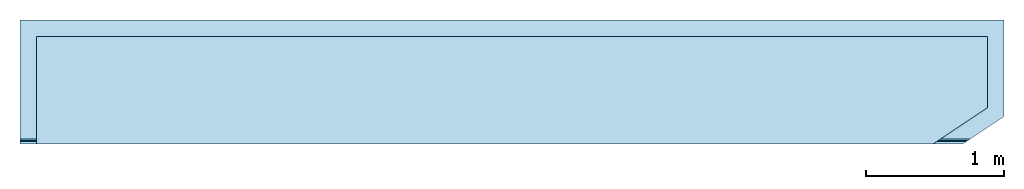
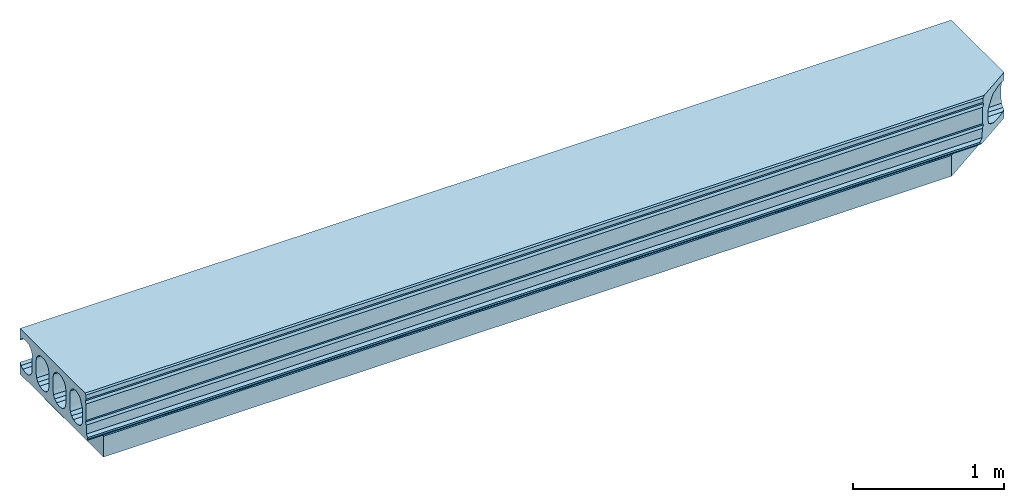
# One storey: 2 slabs.
"""IFC2X3 building model written with IfcOpenShell, lengths in millimetres."""

from ifc_helpers import new_model, si_unit, frame, origin_with_axes, place, context, subcontext, project, spatial, faceted_brep, material, type_object, element, save


model = new_model("IFC2X3")

# Units and contexts
model_context = context("Model", 3, precision=1e-05, world=origin_with_axes())
body_context = subcontext(model_context, "Body", "Model", "MODEL_VIEW")
ifc_project = project(units=[si_unit("LENGTHUNIT", "METRE", prefix="MILLI"), si_unit("AREAUNIT", "SQUARE_METRE"), si_unit("VOLUMEUNIT", "CUBIC_METRE"), si_unit("MASSUNIT", "GRAM", prefix="KILO"), si_unit("TIMEUNIT", "SECOND"), si_unit("PLANEANGLEUNIT", "RADIAN"), si_unit("SOLIDANGLEUNIT", "STERADIAN"), si_unit("THERMODYNAMICTEMPERATUREUNIT", "DEGREE_CELSIUS"), si_unit("LUMINOUSINTENSITYUNIT", "LUMEN")], contexts=[model_context])

# Site, building, storey
site_placement = place(None, origin_with_axes())
site = spatial("IfcSite", under=ifc_project, at=site_placement, CompositionType="ELEMENT")
building_placement = place(site_placement, origin_with_axes())
building = spatial("IfcBuilding", under=site, at=building_placement, Name="Undefined", CompositionType="ELEMENT")
storey_placement = place(building_placement, origin_with_axes())
storey = spatial("IfcBuildingStorey", under=building, at=storey_placement, Name="Undefined", CompositionType="ELEMENT", Elevation=0.0)

# Slabs
ifc_material_1 = material(Name="CONCRETE/Concrete_Undefined")
slab_type_1 = type_object("IfcSlabType", Name="EO37", PredefinedType="NOTDEFINED")
slab_1_placement = place(storey_placement, frame((0.0, 0.0, 185.0), z_axis=(0.0, 0.0, 1.0), x_axis=(1.0, 0.0, 0.0)))
element("IfcSlab", 1, at=slab_1_placement, inside=storey, type_object=slab_type_1, material=ifc_material_1, ObjectType="EO37", PredefinedType="FLOOR", context=body_context, shape_type="Brep", body=[
    faceted_brep([(0.0, -409.398748676134, -124.290964938346), (0.0, -438.100006103516, -130.0), (7082.9999688171, -438.100006103516, -130.0), (7126.05185754527, -409.398748676134, -124.290964938346), (7140.0, -385.066997514525, -108.033008588991), (0.0, -385.066997514525, -108.033008588991), (7140.0, -400.099987598431, -118.07773142711), (0.0, -368.809041165169, -83.7012574273817), (7140.0, -368.809041165169, -83.7012574273817), (0.0, -363.100006103516, -55.0), (7140.0, -363.100006103516, -55.0), (0.0, -363.100006103516, 55.0), (7140.0, -363.100006103516, 55.0), (0.0, -368.809041165169, 83.7012574273817), (7140.0, -368.809041165169, 83.7012574273817), (0.0, -385.066997514525, 108.033008588991), (7140.0, -385.066997514525, 108.033008588991), (0.0, -409.398748676134, 124.290964938347), (7140.0, -400.099987598431, 118.07773142711), (7126.05185754527, -409.398748676134, 124.290964938347), (0.0, -438.100006103516, 130.0), (7082.9999688171, -438.100006103516, 130.0), (0.0, -440.905458547625, 130.0), (7078.79178989805, -440.905458547625, 130.0), (0.0, -444.476831797178, 129.864952985487), (7073.4347297018, -444.476831797178, 129.864952985487), (0.0, -448.027807676442, 129.460583243007), (7068.10826556283, -448.027807676442, 129.460583243007), (0.0, -451.538105311693, 128.789200270557), (7062.84281879354, -451.538105311693, 128.789200270557), (0.0, -454.987676156985, 127.85463857272), (7057.66846221466, -454.987676156985, 127.85463857272), (0.0, -474.113683490167, 121.888653832883), (7028.97944949089, -474.113683490167, 121.888653832883), (0.0, -483.190791183214, 117.975054935726), (7015.36378713312, -483.190791183214, 117.975054935726), (0.0, -491.256055131865, 112.260017067295), (7003.26589048315, -491.256055131865, 112.260017067295), (0.0, -497.957099488949, 104.993233396137), (6993.2143233435, -497.957099488949, 104.993233396137), (0.0, -503.001151916536, 96.4921937240296), (6985.64824424746, -503.001151916536, 96.4921937240296), (0.0, -526.058454074776, 46.3241102051714), (6951.06228893174, -526.058454074776, 46.3241102051714), (0.0, -529.022615447613, 38.8403279823523), (6946.6160466053, -529.022615447613, 38.8403279823523), (0.0, -531.167660399297, 31.0819756342013), (6943.39847898442, -531.167660399297, 31.0819756342013), (0.0, -532.468880586419, 23.1384200683711), (6941.44664858645, -532.468880586419, 23.1384200683711), (0.0, -532.911287514118, 15.1011615113052), (6940.78303815502, -532.911287514118, 15.1011615113052), (0.0, -533.002319524285, -54.9024708467264), (6940.64649013156, -533.002319524285, -54.9024708467264), (0.0, -527.321307017782, -83.6336648774161), (6949.1680094034, -527.321307017782, -83.6336648774161), (0.0, -511.069862086386, -107.998515608949), (6973.54517826538, -511.069862086386, -107.998515608949), (0.0, -486.72616515099, -124.281630576477), (7010.06072586278, -486.72616515099, -124.281630576477), (0.0, -458.002382937217, -130.0), (7053.14640177257, -458.002382937217, -130.0), (0.0, 299.900024414063, -185.0), (0.0, 299.900024414063, -88.6264888460579), (7140.0, 299.900024414063, -88.6264888460579), (7140.0, 299.900024414063, -185.0), (0.0, 286.933002485475, -108.033008588991), (7140.0, 286.933002485475, -108.033008588991), (0.0, 262.601251323866, -124.290964938346), (7140.0, 262.601251323866, -124.290964938346), (0.0, 233.899993896484, -130.0), (7140.0, 233.899993896484, -130.0), (0.0, 213.899993896484, -130.0), (7140.0, 213.899993896484, -130.0), (0.0, 185.198736469103, -124.290964938347), (7140.0, 185.198736469103, -124.290964938347), (0.0, 160.866985307493, -108.033008588991), (7140.0, 160.866985307493, -108.033008588991), (0.0, 144.609028958138, -83.7012574273817), (7140.0, 144.609028958138, -83.7012574273817), (0.0, 138.899993896484, -55.0), (7140.0, 138.899993896484, -55.0), (0.0, 138.899993896484, 55.0), (7140.0, 138.899993896484, 55.0), (0.0, 144.609028958138, 83.7012574273817), (7140.0, 144.609028958138, 83.7012574273817), (0.0, 160.866985307493, 108.033008588991), (7140.0, 160.866985307493, 108.033008588991), (0.0, 185.198736469103, 124.290964938347), (7140.0, 185.198736469103, 124.290964938347), (0.0, 213.899993896484, 130.0), (7140.0, 213.899993896484, 130.0), (0.0, 233.899993896484, 130.0), (7140.0, 233.899993896484, 130.0), (0.0, 262.601251323866, 124.290964938347), (7140.0, 262.601251323866, 124.290964938347), (0.0, 286.933002485475, 108.033008588991), (7140.0, 286.933002485475, 108.033008588991), (0.0, 299.900024414063, 88.6264888460579), (7140.0, 299.900024414063, 88.6264888460579), (0.0, 299.900024414063, 185.0), (7140.0, 299.900024414063, 185.0), (0.0, -185.398748676134, -124.290964938346), (0.0, -214.100006103516, -130.0), (7140.0, -214.100006103516, -130.0), (7140.0, -185.398748676134, -124.290964938346), (0.0, -161.066997514525, -108.033008588991), (7140.0, -161.066997514525, -108.033008588991), (0.0, -144.809041165169, -83.7012574273817), (7140.0, -144.809041165169, -83.7012574273817), (0.0, -139.100006103516, -55.0), (7140.0, -139.100006103516, -55.0), (0.0, -139.100006103516, 55.0), (7140.0, -139.100006103516, 55.0), (0.0, -144.809041165169, 83.7012574273817), (7140.0, -144.809041165169, 83.7012574273817), (0.0, -161.066997514525, 108.033008588991), (7140.0, -161.066997514525, 108.033008588991), (0.0, -185.398748676134, 124.290964938347), (7140.0, -185.398748676134, 124.290964938347), (0.0, -214.100006103516, 130.0), (7140.0, -214.100006103516, 130.0), (0.0, -234.100006103516, 130.0), (7140.0, -234.100006103516, 130.0), (0.0, -262.801263530897, 124.290964938347), (7140.0, -262.801263530897, 124.290964938347), (0.0, -287.133014692507, 108.033008588991), (7140.0, -287.133014692507, 108.033008588991), (0.0, -303.390971041862, 83.7012574273817), (7140.0, -303.390971041862, 83.7012574273817), (0.0, -309.100006103516, 55.0), (7140.0, -309.100006103516, 55.0), (0.0, -309.100006103516, -55.0), (7140.0, -309.100006103516, -55.0), (0.0, -303.390971041862, -83.7012574273817), (7140.0, -303.390971041862, -83.7012574273817), (0.0, -287.133014692507, -108.033008588991), (7140.0, -287.133014692507, -108.033008588991), (0.0, -262.801263530897, -124.290964938347), (7140.0, -262.801263530897, -124.290964938347), (0.0, -234.100006103516, -130.0), (7140.0, -234.100006103516, -130.0), (0.0, -587.070007324219, -185.0), (0.0, -597.099975585938, -170.960006713867), (0.0, -600.099975585938, -155.0), (0.0, -581.919982910156, -137.149993896484), (0.0, -580.070007324219, -65.4400024414063), (0.0, -570.739990234375, -46.5400009155273), (0.0, -579.840026855469, -27.5400009155273), (0.0, -577.330017089844, 103.709999084473), (0.0, -567.640014648438, 122.650001525879), (0.0, -576.739990234375, 141.880004882813), (0.0, -575.22998046875, 174.970001220703), (0.0, -565.039978027344, 185.0), (0.0, 38.6012589532606, -124.290964938347), (0.0, 62.93301011487, -108.033008588991), (0.0, 79.1909664642254, -83.7012574273817), (0.0, 84.9000015258789, -55.0), (0.0, 84.9000015258789, 55.0), (0.0, 79.1909664642254, 83.7012574273817), (0.0, 62.93301011487, 108.033008588991), (0.0, 38.6012589532606, 124.290964938347), (0.0, 9.90000152587889, 130.0), (0.0, -10.0999984741211, 130.0), (0.0, -38.8012559015028, 124.290964938347), (0.0, -63.1330070631122, 108.033008588991), (0.0, -79.3909634124676, 83.7012574273817), (0.0, -85.0999984741211, 55.0), (0.0, -85.0999984741211, -55.0), (0.0, -79.3909634124676, -83.7012574273817), (0.0, -63.1330070631121, -108.033008588991), (0.0, -38.8012559015028, -124.290964938347), (0.0, -10.0999984741211, -130.0), (0.0, 9.90000152587889, -130.0), (7140.0, 9.90000152587889, -130.0), (7140.0, 38.6012589532606, -124.290964938347), (7140.0, 62.93301011487, -108.033008588991), (7140.0, 79.1909664642254, -83.7012574273817), (7140.0, 84.9000015258789, -55.0), (7140.0, 84.9000015258789, 55.0), (7140.0, 79.1909664642254, 83.7012574273817), (7140.0, 62.93301011487, 108.033008588991), (7140.0, 38.6012589532606, 124.290964938347), (7140.0, 9.90000152587889, 130.0), (7140.0, -10.0999984741211, 130.0), (7140.0, -38.8012559015028, 124.290964938347), (7140.0, -63.1330070631122, 108.033008588991), (7140.0, -79.3909634124676, 83.7012574273817), (7140.0, -85.0999984741211, 55.0), (7140.0, -85.0999984741211, -55.0), (7140.0, -79.3909634124676, -83.7012574273817), (7140.0, -63.1330070631121, -108.033008588991), (7140.0, -38.8012559015028, -124.290964938347), (7140.0, -10.0999984741211, -130.0), (7140.0, -400.099987598432, -185.0), (7140.0, -400.099987598432, 185.0), (6859.54495355807, -587.070007324219, -185.0), (6844.5000002614, -597.099975585938, -170.960006713867), (6839.99999999098, -600.099975585938, -155.0), (6867.26999064338, -581.919982910156, -137.149993896484), (6870.04495418904, -580.070007324219, -65.4400024414063), (6884.0399806648, -570.739990234375, -46.5400009155273), (6870.38992491289, -579.840026855469, -27.5400009155273), (6874.15493978758, -577.330017089844, 103.709999084473), (6888.68994432313, -567.640014648438, 122.650001525879), (6875.03998012397, -576.739990234375, 141.880004882813), (6877.30499490851, -575.22998046875, 174.970001220703), (6892.58999948914, -565.039978027344, 185.0)], [[[0, 1, 2, 3]], [[4, 5, 0, 3, 6]], [[7, 5, 4, 8]], [[9, 7, 8, 10]], [[11, 9, 10, 12]], [[13, 11, 12, 14]], [[15, 13, 14, 16]], [[17, 15, 16, 18, 19]], [[20, 17, 19, 21]], [[22, 20, 21, 23]], [[24, 22, 23, 25]], [[26, 24, 25, 27]], [[28, 26, 27, 29]], [[30, 28, 29, 31]], [[32, 30, 31, 33]], [[34, 32, 33, 35]], [[36, 34, 35, 37]], [[38, 36, 37, 39]], [[40, 38, 39, 41]], [[42, 40, 41, 43]], [[44, 42, 43, 45]], [[46, 44, 45, 47]], [[48, 46, 47, 49]], [[50, 48, 49, 51]], [[52, 50, 51, 53]], [[54, 52, 53, 55]], [[56, 54, 55, 57]], [[58, 56, 57, 59]], [[60, 58, 59, 61]], [[1, 60, 61, 2]], [[62, 63, 64, 65]], [[66, 67, 64, 63]], [[66, 68, 69, 67]], [[68, 70, 71, 69]], [[70, 72, 73, 71]], [[72, 74, 75, 73]], [[74, 76, 77, 75]], [[76, 78, 79, 77]], [[78, 80, 81, 79]], [[80, 82, 83, 81]], [[82, 84, 85, 83]], [[84, 86, 87, 85]], [[86, 88, 89, 87]], [[88, 90, 91, 89]], [[90, 92, 93, 91]], [[92, 94, 95, 93]], [[94, 96, 97, 95]], [[97, 96, 98, 99]], [[98, 100, 101, 99]], [[102, 103, 104, 105]], [[106, 102, 105, 107]], [[108, 106, 107, 109]], [[110, 108, 109, 111]], [[112, 110, 111, 113]], [[114, 112, 113, 115]], [[116, 114, 115, 117]], [[118, 116, 117, 119]], [[120, 118, 119, 121]], [[122, 120, 121, 123]], [[124, 122, 123, 125]], [[126, 124, 125, 127]], [[128, 126, 127, 129]], [[130, 128, 129, 131]], [[132, 130, 131, 133]], [[134, 132, 133, 135]], [[136, 134, 135, 137]], [[138, 136, 137, 139]], [[140, 138, 139, 141]], [[103, 140, 141, 104]], [[96, 94, 92, 90, 88, 86, 84, 82, 80, 78, 76, 74, 72, 70, 68, 66, 63, 62, 142, 143, 144, 145, 146, 147, 148, 149, 150, 151, 152, 153, 100, 98], [102, 106, 108, 110, 112, 114, 116, 118, 120, 122, 124, 126, 128, 130, 132, 134, 136, 138, 140, 103], [154, 155, 156, 157, 158, 159, 160, 161, 162, 163, 164, 165, 166, 167, 168, 169, 170, 171, 172, 173], [0, 5, 7, 9, 11, 13, 15, 17, 20, 22, 24, 26, 28, 30, 32, 34, 36, 38, 40, 42, 44, 46, 48, 50, 52, 54, 56, 58, 60, 1]], [[154, 173, 174, 175]], [[155, 154, 175, 176]], [[156, 155, 176, 177]], [[157, 156, 177, 178]], [[158, 157, 178, 179]], [[159, 158, 179, 180]], [[160, 159, 180, 181]], [[161, 160, 181, 182]], [[162, 161, 182, 183]], [[163, 162, 183, 184]], [[164, 163, 184, 185]], [[165, 164, 185, 186]], [[166, 165, 186, 187]], [[167, 166, 187, 188]], [[168, 167, 188, 189]], [[169, 168, 189, 190]], [[170, 169, 190, 191]], [[171, 170, 191, 192]], [[172, 171, 192, 193]], [[173, 172, 193, 174]], [[16, 14, 12, 10, 8, 4, 6, 194, 65, 64, 67, 69, 71, 73, 75, 77, 79, 81, 83, 85, 87, 89, 91, 93, 95, 97, 99, 101, 195, 18], [192, 191, 190, 189, 188, 187, 186, 185, 184, 183, 182, 181, 180, 179, 178, 177, 176, 175, 174, 193], [139, 137, 135, 133, 131, 129, 127, 125, 123, 121, 119, 117, 115, 113, 111, 109, 107, 105, 104, 141]], [[142, 62, 65, 194, 196]], [[143, 142, 196, 197]], [[144, 143, 197, 198]], [[145, 144, 198, 199]], [[146, 145, 199, 200]], [[147, 146, 200, 201]], [[148, 147, 201, 202]], [[149, 148, 202, 203]], [[150, 149, 203, 204]], [[151, 150, 204, 205]], [[152, 151, 205, 206]], [[153, 152, 206, 207]], [[101, 100, 153, 207, 195]], [[206, 205, 204, 203, 202, 201, 200, 199, 198, 197, 196, 194, 6, 3, 2, 61, 59, 57, 55, 53, 51, 49, 47, 45, 43, 41, 39, 37, 35, 33, 31, 29, 27, 25, 23, 21, 19, 18, 195, 207]]]),
])
ifc_material_2 = material(Name="EPS Ultra 80S")
slab_type_2 = type_object("IfcSlabType", PredefinedType="NOTDEFINED")
slab_2_placement = place(storey_placement, frame((120.0, 179.900024414063, -85.0), z_axis=(1.0, 0.0, 0.0), x_axis=(0.0, -1.0, 0.0)))
element("IfcSlab", 2, at=slab_2_placement, inside=storey, type_object=slab_type_2, material=ifc_material_2, PredefinedType="FLOOR", context=body_context, shape_type="Brep", body=[
    faceted_brep([(0.0, -85.0, 0.0), (-3.04708578369173e-08, -85.0, 6900.0), (-3.04708578369173e-08, 85.0, 6900.0), (0.0, 85.0, 0.0), (515.777954101563, -85.0, 6900.0), (515.777954101563, 85.0, 6900.0), (780.0, -85.0, 6503.6669921875), (780.0, 85.0, 6503.6669921875), (780.0, -85.0, -3.5242919693701e-12), (780.0, 85.0, -3.5242919693701e-12)], [[[0, 1, 2, 3]], [[1, 4, 5, 2]], [[4, 6, 7, 5]], [[6, 8, 9, 7]], [[8, 0, 3, 9]], [[5, 7, 9, 3, 2]], [[8, 6, 4, 1, 0]]]),
])

save(model, "model.ifc")
